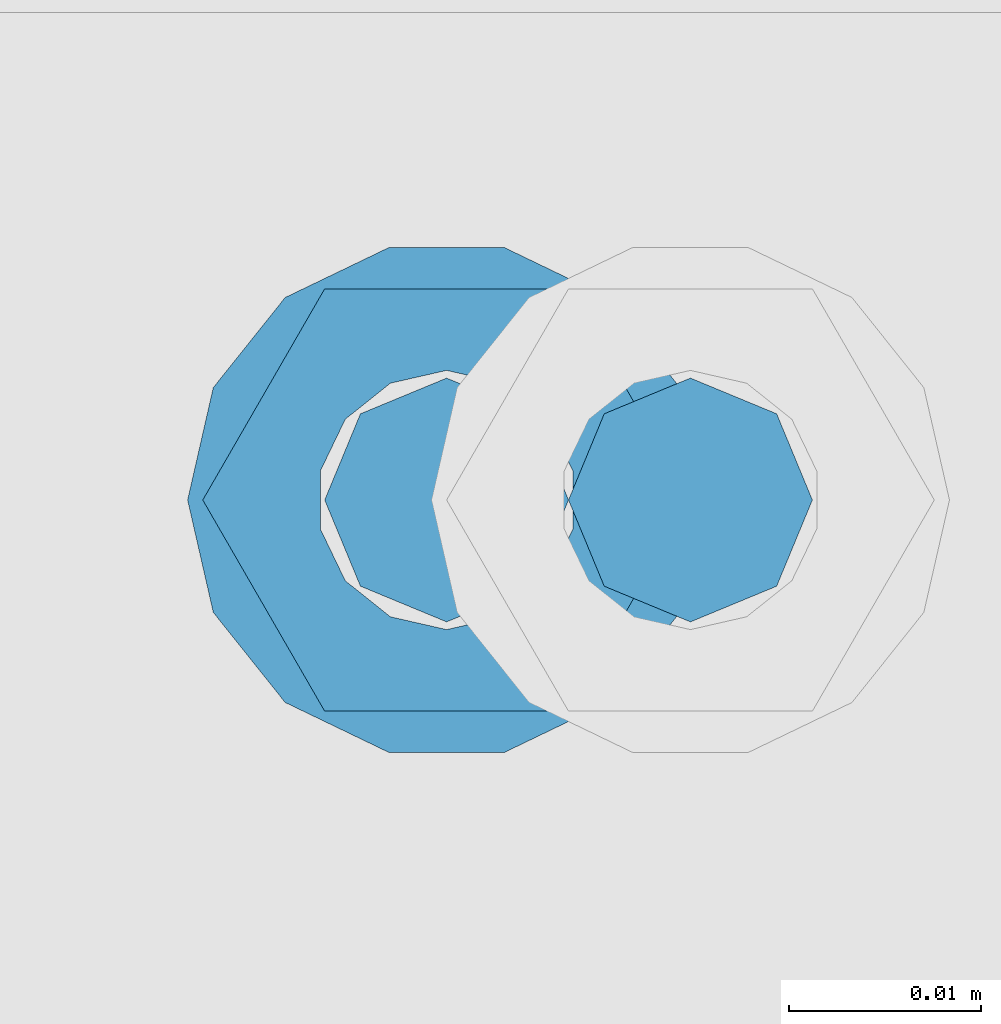
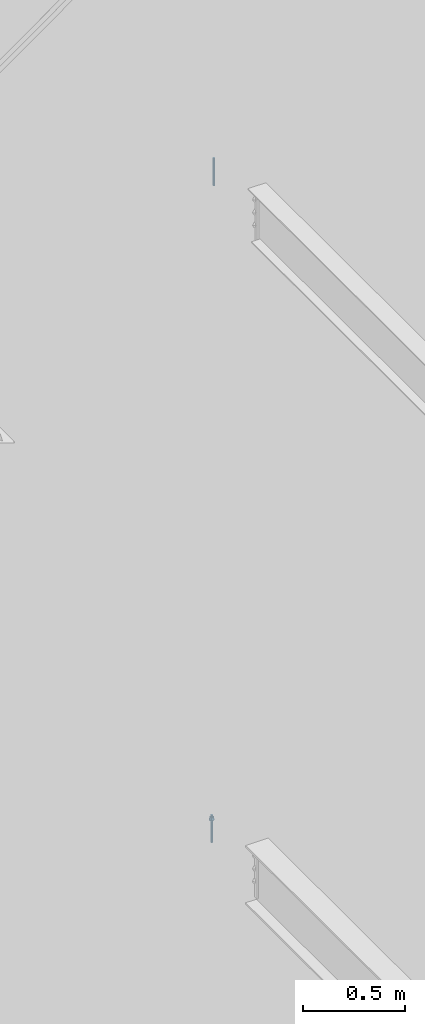
# One storey, part 568 of 1179: 2 columns, 2 elements without a shape of their own.
"""IFC2X3 building model written with IfcOpenShell, lengths in millimetres."""

import ifcopenshell
import ifcopenshell.guid

model = None  # the IFC model being written
_history = None  # IfcOwnerHistory: only IFC2X3 demands one
_inside = {}  # id of a spatial element -> (the spatial element, [elements in it])
_under = {}  # id of a project, library or spatial element -> (it, [spatial elements below it])
_declared = {}  # id of a project -> (the project, [libraries it declares])
_typed = {}  # id of a type object -> (the type object, [elements of that type])
_made_of = {}  # id of a material, layer set ... -> (it, [elements and type objects made of it])


def new_model(schema):
    """Start an empty IFC model of exactly this schema.

    Asked for "IFC4X3", IfcOpenShell would pick the latest addendum, in which some entities
    have other attributes; the version numbers below select the first issue.
    IFC2X3 requires an IfcOwnerHistory on every rooted entity: one is made here for all.
    """
    global model, _history
    if schema == "IFC4X3":
        model = ifcopenshell.file(schema_version=(4, 3, 0, 0))
    else:
        model = ifcopenshell.file(schema=schema)
    _inside.clear()
    _under.clear()
    _declared.clear()
    _typed.clear()
    _made_of.clear()
    _history = None
    if model.schema == "IFC2X3":
        org = make("IfcOrganization", Name="unknown")
        user = make(
            "IfcPersonAndOrganization",
            ThePerson=make("IfcPerson", FamilyName="unknown"),
            TheOrganization=org,
        )
        app = make(
            "IfcApplication",
            ApplicationDeveloper=org,
            Version="unknown",
            ApplicationFullName="unknown",
            ApplicationIdentifier="unknown",
        )
        _history = make(
            "IfcOwnerHistory",
            OwningUser=user,
            OwningApplication=app,
            ChangeAction="ADDED",
            CreationDate=0,
        )
    return model


def make(cls, **values):
    """One entity of the class cls with the attributes given. An attribute that is None is left unset."""
    return model.create_entity(
        cls, **{name: value for name, value in values.items() if value is not None}
    )


def rooted(cls, **values):
    """An entity with a GlobalId (a new one), such as an element, a storey or a relation."""
    return make(cls, GlobalId=ifcopenshell.guid.new(), OwnerHistory=_history, **values)


def si_unit(unit_type, name, prefix=None):
    """IfcSIUnit, for example si_unit("LENGTHUNIT", "METRE", prefix="MILLI")."""
    return make("IfcSIUnit", UnitType=unit_type, Prefix=prefix, Name=name)


def assignment(units):
    """IfcUnitAssignment: the units of a project."""
    return None if units is None else make("IfcUnitAssignment", Units=units)


def point(xyz):
    """IfcCartesianPoint."""
    return None if xyz is None else make("IfcCartesianPoint", Coordinates=xyz)


def direction(xyz):
    """IfcDirection."""
    return None if xyz is None else make("IfcDirection", DirectionRatios=xyz)


def frame(location, z_axis=None, x_axis=None):
    """IfcAxis2Placement3D, a coordinate frame: its origin and axes. An axis left out is left unset."""
    return make(
        "IfcAxis2Placement3D",
        Location=point(location),
        Axis=direction(z_axis),
        RefDirection=direction(x_axis),
    )


def origin_with_axes():
    """The frame at (0, 0, 0) with the z axis (0, 0, 1) and the x axis (1, 0, 0) written out."""
    return frame((0.0, 0.0, 0.0), z_axis=(0.0, 0.0, 1.0), x_axis=(1.0, 0.0, 0.0))


def place(relative_to, where):
    """IfcLocalPlacement: puts the frame where relative to a parent placement (None: the world)."""
    return make(
        "IfcLocalPlacement", PlacementRelTo=relative_to, RelativePlacement=where
    )


def context(
    kind, dimensions, precision=None, world=None, true_north=None, identifier=None
):
    """IfcGeometricRepresentationContext, for example the 3D "Model" context."""
    return make(
        "IfcGeometricRepresentationContext",
        ContextIdentifier=identifier,
        ContextType=kind,
        CoordinateSpaceDimension=dimensions,
        Precision=precision,
        WorldCoordinateSystem=world,
        TrueNorth=true_north,
    )


def subcontext(parent, identifier, kind, view, scale=None):
    """IfcGeometricRepresentationSubContext, for example "Body" below "Model"."""
    return make(
        "IfcGeometricRepresentationSubContext",
        ContextIdentifier=identifier,
        ContextType=kind,
        ParentContext=parent,
        TargetScale=scale,
        TargetView=view,
    )


def project(units=None, contexts=None):
    """IfcProject with its units and contexts."""
    return rooted(
        "IfcProject",
        Name="project",
        RepresentationContexts=contexts,
        UnitsInContext=assignment(units),
    )


def spatial(cls, under=None, at=None, **own):
    """A site, building, storey or space (cls), placed at a placement, below another one or the project."""
    s = rooted(cls, ObjectPlacement=at, **own)
    if under is not None:
        _under.setdefault(under.id(), (under, []))[1].append(s)
    return s


def faces_of(points, faces, orient=None, outer=None):
    """IfcFace entities. A face is a list of loops; a loop is a list of indices into points, from 0.

    orient and outer hold one flag for each loop. By default every Orientation is true, the
    first loop of a face is its IfcFaceOuterBound and the others are IfcFaceBound.
    """
    made = []
    for i, loops in enumerate(faces):
        bounds = []
        for j, loop in enumerate(loops):
            is_outer = j == 0 if outer is None else outer[i][j]
            bounds.append(
                make(
                    "IfcFaceOuterBound" if is_outer else "IfcFaceBound",
                    Bound=make("IfcPolyLoop", Polygon=[points[k] for k in loop]),
                    Orientation=True if orient is None else orient[i][j],
                )
            )
        made.append(make("IfcFace", Bounds=bounds))
    return made


def faceted_brep(points, faces, orient=None, outer=None, voids=None):
    """IfcFacetedBrep: a solid bounded by flat faces; with voids (closed shells), ...WithVoids."""
    shared = [point(p) for p in points]
    hull = make("IfcClosedShell", CfsFaces=faces_of(shared, faces, orient, outer))
    if voids is None:
        return make("IfcFacetedBrep", Outer=hull)
    return make(
        "IfcFacetedBrepWithVoids",
        Outer=hull,
        Voids=[
            make(cls, CfsFaces=faces_of(shared, fs, o, b)) for cls, fs, o, b in voids
        ],
    )


def shape(context_of_items, identifier, shape_type, items):
    """IfcShapeRepresentation: the items that make up one representation, for example the "Body"."""
    return make(
        "IfcShapeRepresentation",
        ContextOfItems=context_of_items,
        RepresentationIdentifier=identifier,
        RepresentationType=shape_type,
        Items=items,
    )


def material(Name=None, Category=None):
    """IfcMaterial."""
    return make("IfcMaterial", Name=Name, Category=Category)


def made_of(thing, what):
    """Note that an element or type object is made of a material, layer set ...; save() writes the relation."""
    if what is not None:
        _made_of.setdefault(what.id(), (what, []))[1].append(thing)
    return thing


def type_object(cls, material=None, **own):
    """A type object (cls), such as IfcWallType, which elements share."""
    return made_of(rooted(cls, **own), material)


def element(
    cls,
    number,
    at=None,
    inside=None,
    cuts=None,
    type_object=None,
    material=None,
    context=None,
    identifier="Body",
    shape_type=None,
    held_by="IfcProductDefinitionShape",
    body=None,
    shapes=None,
    **own,
):
    """One element of the class cls, such as IfcWall. Its Tag is "e" and its number.

    at: its placement. inside: the storey or other place that contains it. cuts: it is an
    opening in that element (IfcRelVoidsElement). A single representation is given by context,
    identifier, shape_type and body (its items); several are given by shapes. held_by: the class
    of the entity that holds the representations. save() writes the other relations.
    """
    e = rooted(cls, Tag="e%d" % number, ObjectPlacement=at, **own)
    if body is not None:
        shapes = [shape(context, identifier, shape_type, body)]
    if shapes is not None:
        e.Representation = make(held_by, Representations=shapes)
    if inside is not None:
        _inside.setdefault(inside.id(), (inside, []))[1].append(e)
    if cuts is not None:
        rooted(
            "IfcRelVoidsElement", RelatingBuildingElement=cuts, RelatedOpeningElement=e
        )
    if type_object is not None:
        _typed.setdefault(type_object.id(), (type_object, []))[1].append(e)
    return made_of(e, material)


def aggregate(whole, parts):
    """IfcRelAggregates: a whole, such as a stair, and the parts it consists of."""
    return rooted("IfcRelAggregates", RelatingObject=whole, RelatedObjects=parts)


def save(model, path):
    """Write the relations noted so far, then the file.

    IfcRelAggregates (storeys below a building ...), IfcRelContainedInSpatialStructure (elements
    in a storey), IfcRelDefinesByType, IfcRelAssociatesMaterial and IfcRelDeclares: one each for
    every whole, place, type object, material and project.
    """
    for whole, parts in _under.values():
        aggregate(whole, parts)
    for where, things in _inside.values():
        rooted(
            "IfcRelContainedInSpatialStructure",
            RelatedElements=things,
            RelatingStructure=where,
        )
    for kind, things in _typed.values():
        rooted("IfcRelDefinesByType", RelatedObjects=things, RelatingType=kind)
    for what, things in _made_of.values():
        rooted("IfcRelAssociatesMaterial", RelatedObjects=things, RelatingMaterial=what)
    for by, libraries in _declared.values():
        rooted("IfcRelDeclares", RelatingContext=by, RelatedDefinitions=libraries)
    model.write(path)


model = new_model("IFC2X3")

# Units and contexts
model_context = context("Model", 3, precision=1e-05, world=origin_with_axes())
body_context = subcontext(model_context, "Body", "Model", "MODEL_VIEW")
ifc_project = project(units=[si_unit("LENGTHUNIT", "METRE", prefix="MILLI"), si_unit("AREAUNIT", "SQUARE_METRE"), si_unit("VOLUMEUNIT", "CUBIC_METRE"), si_unit("MASSUNIT", "GRAM", prefix="KILO"), si_unit("TIMEUNIT", "SECOND"), si_unit("PLANEANGLEUNIT", "RADIAN"), si_unit("SOLIDANGLEUNIT", "STERADIAN"), si_unit("THERMODYNAMICTEMPERATUREUNIT", "DEGREE_CELSIUS"), si_unit("LUMINOUSINTENSITYUNIT", "LUMEN")], contexts=[model_context])

# Site, building, storey
site_placement = place(None, origin_with_axes())
site = spatial("IfcSite", under=ifc_project, at=site_placement, CompositionType="ELEMENT")
building_placement = place(site_placement, origin_with_axes())
building = spatial("IfcBuilding", under=site, at=building_placement, Name="Undefined", CompositionType="ELEMENT")
storey_placement = place(building_placement, origin_with_axes())
storey = spatial("IfcBuildingStorey", under=building, at=storey_placement, Name="Undefined", CompositionType="ELEMENT", Elevation=0.0)

# Assembly, column
assembly_1_placement = place(storey_placement, origin_with_axes())
assembly_1 = element("IfcElementAssembly", 1, at=assembly_1_placement, inside=storey, Name="BEAM", AssemblyPlace="NOTDEFINED", PredefinedType="RIGID_FRAME")
ifc_material = material(Name="STEEL/A307")
column_type = type_object("IfcColumnType", PredefinedType="NOTDEFINED")
column_1_placement = place(assembly_1_placement, frame((22146.021875, 37985.7, 8013.7), z_axis=(0.0, 1.0, 0.0), x_axis=(0.0, 0.0, 1.0)))
column_1 = element("IfcColumn", 2, at=column_1_placement, type_object=column_type, material=ifc_material, Name="THREADED ROD", context=body_context, shape_type="Brep", body=[
    faceted_brep([(0.0, -6.34999999999854, 0.0), (0.0, -4.49012806053361, -4.49012806053452), (163.512500000001, -4.49012806053361, -4.49012806053452), (163.512500000001, -6.34999999999854, 0.0), (0.0, 0.0, -6.34999999999991), (163.512500000001, 0.0, -6.35000000000036), (0.0, 4.49012806053361, -4.49012806053452), (163.512500000001, 4.49012806053361, -4.49012806053452), (0.0, 6.34999999999854, 0.0), (163.512500000001, 6.34999999999854, 0.0), (0.0, 4.49012806053361, 4.49012806053452), (163.512500000001, 4.49012806053361, 4.49012806053452), (0.0, 0.0, 6.34999999999991), (163.512500000001, 0.0, 6.35000000000036), (0.0, -4.49012806053361, 4.49012806053452), (163.512500000001, -4.49012806053361, 4.49012806053452)], [[[0, 1, 2, 3]], [[1, 4, 5, 2]], [[4, 6, 7, 5]], [[6, 8, 9, 7]], [[8, 10, 11, 9]], [[10, 12, 13, 11]], [[12, 14, 15, 13]], [[14, 0, 3, 15]], [[5, 7, 9, 11, 13, 15, 3, 2]], [[14, 12, 10, 8, 6, 4, 1, 0]]]),
])
aggregate(assembly_1, [column_1])

assembly_2_placement = place(storey_placement, origin_with_axes())
assembly_2 = element("IfcElementAssembly", 3, at=assembly_2_placement, inside=storey, Name="BEAM", AssemblyPlace="NOTDEFINED", PredefinedType="RIGID_FRAME")
column_2_placement = place(assembly_2_placement, frame((22133.321875, 37985.7, 4102.1), z_axis=(0.0, 1.0, 0.0), x_axis=(0.0, 0.0, 1.0)))
column_2 = element("IfcColumn", 4, at=column_2_placement, type_object=column_type, material=ifc_material, Name="THREADED ROD", context=body_context, shape_type="Brep", body=[
    faceted_brep([(0.0, -4.49012806053361, 4.49012806053452), (0.0, -6.34999999999854, 0.0), (163.512500000001, -6.34999999999854, 0.0), (163.512500000001, -4.49012806053361, 4.49012806053452), (0.0, 0.0, 6.34999999999991), (0.0, 4.49012806053361, 4.49012806053452), (0.0, 6.34999999999854, 0.0), (0.0, 4.49012806053361, -4.49012806053452), (0.0, 0.0, -6.34999999999991), (0.0, -4.49012806053361, -4.49012806053452), (163.512500000001, 0.0, 6.35000000000036), (163.512500000001, 4.49012806053361, 4.49012806053452), (163.512500000001, 6.34999999999854, 0.0), (163.512500000001, 4.49012806053361, -4.49012806053452), (163.512500000001, 0.0, -6.35000000000036), (163.512500000001, -4.49012806053361, -4.49012806053452), (133.349999999999, -12.1540698217887, -5.85309154138668), (133.349999999999, -8.41087728436833, -10.5469065195502), (138.112499999999, -8.41087728436833, -10.5469065195502), (138.112499999999, -12.1540698217887, -5.85309154138668), (133.349999999999, -3.00180734814057, -13.1517773121886), (138.112499999999, -3.00180734814057, -13.1517773121886), (133.349999999999, 3.00180734814057, -13.1517773121886), (138.112499999999, 3.00180734814057, -13.1517773121886), (133.349999999999, 8.41087728436833, -10.5469065195502), (138.112499999999, 8.41087728436833, -10.5469065195502), (133.349999999999, 12.1540698217887, -5.85309154138668), (138.112499999999, 12.1540698217887, -5.85309154138668), (133.349999999999, 13.4899997711182, 0.0), (138.112499999999, 13.4899997711182, 0.0), (133.349999999999, 12.1540698217887, 5.85309154138668), (138.112499999999, 12.1540698217887, 5.85309154138668), (133.349999999999, 8.41087728436833, 10.5469065195502), (138.112499999999, 8.41087728436833, 10.5469065195502), (133.349999999999, 3.00180734814057, 13.1517773121886), (138.112499999999, 3.00180734814057, 13.1517773121886), (133.349999999999, -3.00180734814057, 13.1517773121886), (138.112499999999, -3.00180734814057, 13.1517773121886), (133.349999999999, -8.41087728436833, 10.5469065195502), (138.112499999999, -8.41087728436833, 10.5469065195502), (133.349999999999, -12.1540698217887, 5.85309154138668), (138.112499999999, -12.1540698217887, 5.85309154138668), (133.349999999999, -13.4899997711182, 0.0), (138.112499999999, -13.4899997711182, 0.0), (138.112499999999, -12.6999998092651, 0.0), (138.112499999999, -6.34999990463257, 11.0), (138.112499999999, 6.34999990463257, 11.0), (138.112499999999, 12.6999998092651, 0.0), (138.112499999999, 6.34999990463257, -11.0), (138.112499999999, -6.34999990463257, -11.0), (133.349999999999, -2.92871523904432, 6.0815398583436), (133.349999999999, -5.27736250665839, 4.20855616254994), (133.349999999999, -6.58076340722801, 1.50201630420634), (133.349999999999, -6.58076340722801, -1.50201630420634), (133.349999999999, -5.27736250665839, -4.20855616254994), (133.349999999999, -2.92871523904432, -6.0815398583436), (133.349999999999, 0.0, -6.75), (133.349999999999, 2.92871523904432, -6.0815398583436), (133.349999999999, 5.27736250665839, -4.20855616254994), (133.349999999999, 6.58076340722801, -1.50201630420634), (133.349999999999, 6.58076340722801, 1.50201630420634), (133.349999999999, 5.27736250665839, 4.20855616254994), (133.349999999999, 2.92871523904432, 6.0815398583436), (133.349999999999, 0.0, 6.75), (150.812499999999, -2.92871523904432, 6.0815398583436), (150.812499999999, 0.0, 6.75), (150.812499999999, -5.27736250665839, 4.20855616254994), (150.812499999999, -6.58076340722801, 1.50201630420634), (150.812499999999, -5.27736250665839, -4.20855616254994), (150.812499999999, -6.58076340722801, -1.50201630420634), (150.812499999999, -2.92871523904432, -6.0815398583436), (150.812499999999, 0.0, -6.75), (150.812499999999, 2.92871523904432, -6.0815398583436), (150.812499999999, 5.27736250665839, -4.20855616254994), (150.812499999999, 6.58076340722801, -1.50201630420634), (150.812499999999, 5.27736250665839, 4.20855616254994), (150.812499999999, 6.58076340722801, 1.50201630420634), (150.812499999999, 2.92871523904432, 6.0815398583436), (150.812499999999, -12.6999998092651, 0.0), (150.812499999999, -6.34999990463257, 11.0), (150.812499999999, 6.34999990463257, -11.0), (150.812499999999, -6.34999990463257, -11.0), (150.812499999999, 12.6999998092651, 0.0), (150.812499999999, 6.34999990463257, 11.0)], [[[0, 1, 2, 3]], [[0, 4, 5, 6, 7, 8, 9, 1]], [[5, 4, 10, 11]], [[6, 5, 11, 12]], [[7, 6, 12, 13]], [[8, 7, 13, 14]], [[9, 8, 14, 15]], [[1, 9, 15, 2]], [[14, 13, 12, 11, 10, 3, 2, 15]], [[4, 0, 3, 10]], [[16, 17, 18, 19]], [[17, 20, 21, 18]], [[20, 22, 23, 21]], [[22, 24, 25, 23]], [[24, 26, 27, 25]], [[26, 28, 29, 27]], [[28, 30, 31, 29]], [[30, 32, 33, 31]], [[32, 34, 35, 33]], [[34, 36, 37, 35]], [[36, 38, 39, 37]], [[38, 40, 41, 39]], [[40, 42, 43, 41]], [[18, 21, 23, 25, 27, 29, 31, 33, 35, 37, 39, 41, 43, 19], [44, 45, 46, 47, 48, 49]], [[42, 16, 19, 43]], [[40, 38, 36, 34, 32, 30, 28, 26, 24, 22, 20, 17, 16, 42], [50, 51, 52, 53, 54, 55, 56, 57, 58, 59, 60, 61, 62, 63]], [[64, 50, 63, 65]], [[66, 51, 50, 64]], [[67, 52, 51, 66]], [[68, 54, 53, 69]], [[70, 55, 54, 68]], [[71, 56, 55, 70]], [[72, 57, 56, 71]], [[73, 58, 57, 72]], [[74, 59, 58, 73]], [[75, 61, 60, 76]], [[77, 62, 61, 75]], [[77, 65, 63, 62]], [[78, 79, 45, 44]], [[80, 81, 49, 48]], [[82, 80, 48, 47]], [[83, 82, 47, 46]], [[79, 83, 46, 45]], [[81, 78, 44, 49]], [[53, 52, 67, 69]], [[60, 59, 74, 76]], [[80, 82, 83, 79, 78, 81], [75, 76, 74, 73, 72, 71, 70, 68, 69, 67, 66, 64, 65, 77]]]),
])
aggregate(assembly_2, [column_2])

save(model, "model.ifc")
